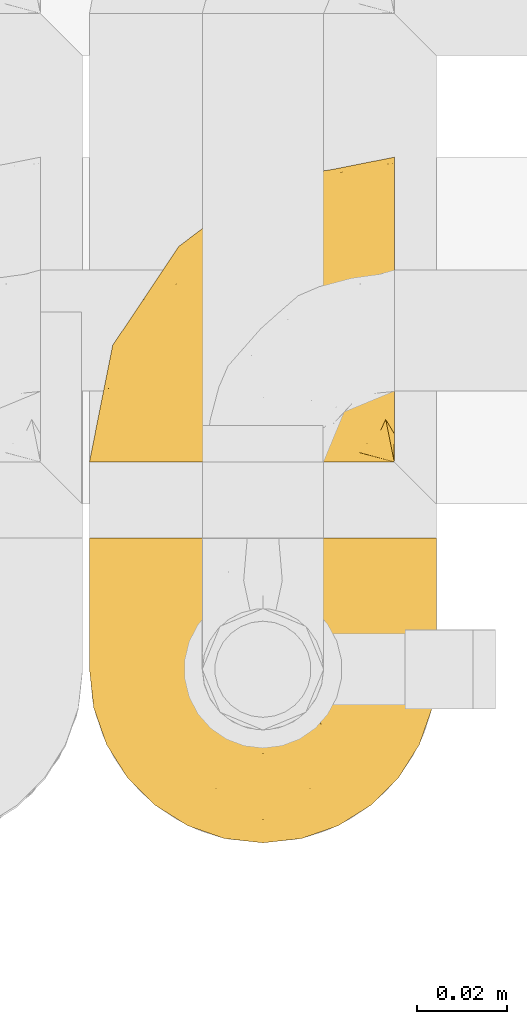
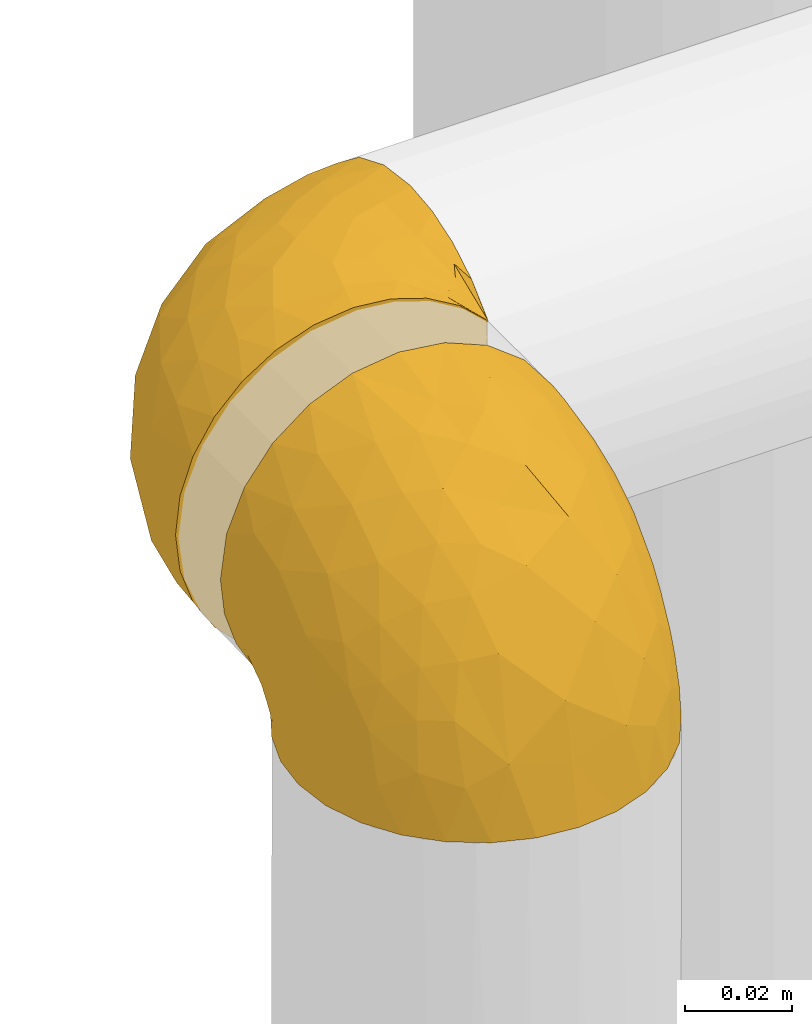
# One storey, part 464 of 827: 2 coverings.
"""IFC2X3 building model written with IfcOpenShell, lengths in millimetres."""

from ifc_helpers import new_model, entity, si_unit, converted_unit, derived_unit, direction, frame, origin, place, context, subcontext, project, spatial, faceted_brep, element, save


model = new_model("IFC2X3")

# Units and contexts
model_context = context("Model", 3, precision=0.01, world=origin(), true_north=direction((6.12303176911189e-17, 1.0)))
body_context = subcontext(model_context, "Body", "Model", "MODEL_VIEW")
ifc_project = project(units=[si_unit("LENGTHUNIT", "METRE", prefix="MILLI"), si_unit("AREAUNIT", "SQUARE_METRE"), si_unit("VOLUMEUNIT", "CUBIC_METRE"), converted_unit("PLANEANGLEUNIT", "DEGREE", entity("IfcRatioMeasure", 0.0174532925199433), si_unit("PLANEANGLEUNIT", "RADIAN"), dimensions=[0, 0, 0, 0, 0, 0, 0]), si_unit("MASSUNIT", "GRAM", prefix="KILO"), derived_unit("MASSDENSITYUNIT", [(si_unit("MASSUNIT", "GRAM", prefix="KILO"), 1), (si_unit("LENGTHUNIT", "METRE"), -3)]), derived_unit("MOMENTOFINERTIAUNIT", [(si_unit("LENGTHUNIT", "METRE"), 4)]), si_unit("TIMEUNIT", "SECOND"), si_unit("FREQUENCYUNIT", "HERTZ"), si_unit("THERMODYNAMICTEMPERATUREUNIT", "DEGREE_CELSIUS"), derived_unit("THERMALTRANSMITTANCEUNIT", [(si_unit("MASSUNIT", "GRAM", prefix="KILO"), 1), (si_unit("THERMODYNAMICTEMPERATUREUNIT", "KELVIN"), -1), (si_unit("TIMEUNIT", "SECOND"), -3)]), derived_unit("VOLUMETRICFLOWRATEUNIT", [(si_unit("LENGTHUNIT", "METRE"), 3), (si_unit("TIMEUNIT", "SECOND"), -1)]), derived_unit("MASSFLOWRATEUNIT", [(si_unit("MASSUNIT", "GRAM", prefix="KILO"), 1), (si_unit("TIMEUNIT", "SECOND"), -1)]), derived_unit("ROTATIONALFREQUENCYUNIT", [(si_unit("TIMEUNIT", "SECOND"), -1)]), si_unit("ELECTRICCURRENTUNIT", "AMPERE"), si_unit("ELECTRICVOLTAGEUNIT", "VOLT"), si_unit("POWERUNIT", "WATT"), si_unit("FORCEUNIT", "NEWTON", prefix="KILO"), si_unit("ILLUMINANCEUNIT", "LUX"), si_unit("LUMINOUSFLUXUNIT", "LUMEN"), si_unit("LUMINOUSINTENSITYUNIT", "CANDELA"), derived_unit("USERDEFINED", [(si_unit("MASSUNIT", "GRAM", prefix="KILO"), -1), (si_unit("LENGTHUNIT", "METRE"), -2), (si_unit("TIMEUNIT", "SECOND"), 3), (si_unit("LUMINOUSFLUXUNIT", "LUMEN"), 1)]), derived_unit("LINEARVELOCITYUNIT", [(si_unit("LENGTHUNIT", "METRE"), 1), (si_unit("TIMEUNIT", "SECOND"), -1)]), si_unit("PRESSUREUNIT", "PASCAL"), derived_unit("USERDEFINED", [(si_unit("LENGTHUNIT", "METRE"), -2), (si_unit("MASSUNIT", "GRAM", prefix="KILO"), 1), (si_unit("TIMEUNIT", "SECOND"), -2)]), derived_unit("LINEARFORCEUNIT", [(si_unit("MASSUNIT", "GRAM", prefix="KILO"), 1), (si_unit("LENGTHUNIT", "METRE"), 1), (si_unit("TIMEUNIT", "SECOND"), -2), (si_unit("LENGTHUNIT", "METRE"), -1)]), derived_unit("PLANARFORCEUNIT", [(si_unit("MASSUNIT", "GRAM", prefix="KILO"), 1), (si_unit("LENGTHUNIT", "METRE"), 1), (si_unit("TIMEUNIT", "SECOND"), -2), (si_unit("LENGTHUNIT", "METRE"), -2)])], contexts=[model_context])

# Site, building, storey
site_placement = place(None, origin())
site = spatial("IfcSite", under=ifc_project, at=site_placement, CompositionType="ELEMENT")
building_placement = place(site_placement, origin())
building = spatial("IfcBuilding", under=site, at=building_placement, CompositionType="ELEMENT")
storey_placement = place(building_placement, frame((0.0, 0.0, 28200.0)))
storey = spatial("IfcBuildingStorey", under=building, at=storey_placement, Name="08", CompositionType="ELEMENT", Elevation=28200.0)

# Coverings
covering_1_placement = place(storey_placement, frame((58529.55, 16349.14, 2609.95)))
element("IfcCovering", 1, at=covering_1_placement, inside=storey, Name=":ADSK_", ObjectType=":ADSK_", PredefinedType="INSULATION", context=body_context, shape_type="Brep", body=[
    faceted_brep([(23.36, 1.6, 74.68), (16.07, 1.6, 70.1), (9.98, 1.6, 64.01), (5.4, 1.6, 56.72), (2.56, 1.6, 48.6), (1.6, 1.6, 40.05), (2.56, 1.6, 31.49), (5.41, 1.6, 23.36), (9.99, 1.6, 16.07), (16.08, 1.6, 9.98), (23.37, 1.6, 5.4), (31.49, 1.6, 2.56), (40.05, 1.6, 1.6), (48.15, 1.6, 2.46), (55.88, 1.6, 5.01), (62.9, 1.6, 9.13), (68.89, 1.6, 14.62), (68.89, 1.6, 16.82), (68.89, 1.6, 18.56), (68.89, 1.6, 20.52), (68.89, 1.6, 22.49), (68.89, 1.6, 24.46), (68.89, 1.6, 26.42), (68.89, 1.6, 28.39), (68.89, 1.6, 30.36), (68.89, 1.6, 32.55), (68.89, 1.6, 34.75), (68.89, 1.6, 36.94), (68.89, 1.6, 39.13), (68.89, 1.6, 41.33), (68.89, 1.6, 43.52), (68.89, 1.6, 45.72), (68.89, 1.6, 47.91), (68.89, 1.6, 50.11), (68.89, 1.6, 52.3), (68.89, 1.6, 54.49), (68.89, 1.6, 56.69), (68.89, 1.6, 58.88), (68.89, 1.6, 61.08), (68.89, 1.6, 63.27), (68.89, 1.6, 65.47), (62.89, 1.6, 70.97), (55.86, 1.6, 75.09), (48.13, 1.6, 77.64), (40.05, 1.6, 78.5), (31.49, 1.6, 77.53), (69.15, 1.85, 14.62), (69.15, 7.85, 9.12), (69.15, 14.87, 5.0), (69.15, 22.6, 2.46), (69.15, 30.7, 1.6), (69.15, 40.65, 2.91), (69.15, 49.92, 6.75), (69.15, 57.88, 12.86), (69.15, 63.99, 20.82), (69.15, 67.84, 30.09), (69.15, 69.15, 40.05), (69.15, 67.84, 50.0), (69.15, 63.99, 59.27), (69.15, 57.88, 67.23), (69.15, 49.92, 73.34), (69.15, 40.65, 77.19), (69.15, 30.7, 78.5), (69.15, 22.6, 77.63), (69.15, 14.87, 75.09), (69.15, 7.85, 70.97), (69.15, 1.85, 65.47), (69.15, 1.85, 63.27), (69.15, 1.85, 62.29), (69.15, 1.85, 60.7), (69.15, 1.85, 59.11), (69.15, 1.85, 57.52), (69.15, 1.85, 55.93), (69.15, 1.85, 54.34), (69.15, 1.85, 52.76), (69.15, 1.85, 51.17), (69.15, 1.85, 49.58), (69.15, 1.85, 47.99), (69.15, 1.85, 46.4), (69.15, 1.85, 44.81), (69.15, 1.85, 43.22), (69.15, 1.85, 41.63), (69.15, 1.85, 40.05), (69.15, 1.85, 38.46), (69.15, 1.85, 36.87), (69.15, 1.85, 35.28), (69.15, 1.85, 33.69), (69.15, 1.85, 32.1), (69.15, 1.85, 30.51), (69.15, 1.85, 28.92), (69.15, 1.85, 27.33), (69.15, 1.85, 25.37), (69.15, 1.85, 23.4), (69.15, 1.85, 21.21), (69.15, 1.85, 19.01), (69.15, 1.85, 16.82), (68.96, 1.77, 42.32), (68.97, 1.78, 44.02), (68.97, 1.77, 47.13), (68.97, 1.77, 48.74), (68.95, 1.76, 23.57), (68.96, 1.77, 25.13), (68.98, 1.79, 61.34), (68.97, 1.78, 22.02), (68.97, 1.78, 29.72), (68.98, 1.78, 56.73), (68.97, 1.78, 55.14), (68.97, 1.78, 37.66), (68.94, 1.74, 64.12), (68.98, 1.78, 28.13), (68.98, 1.78, 26.62), (68.96, 1.77, 31.46), (68.97, 1.78, 16.16), (68.98, 1.78, 39.16), (68.98, 1.78, 50.37), (68.97, 1.77, 17.69), (68.96, 1.77, 19.17), (68.97, 1.77, 62.78), (68.97, 1.78, 58.35), (68.98, 1.78, 45.53), (68.96, 1.77, 59.91), (68.97, 1.77, 65.47), (68.94, 1.72, 65.47), (68.92, 1.66, 65.47), (68.97, 1.77, 14.62), (69.02, 1.8, 14.62), (69.08, 1.82, 14.62), (68.98, 1.79, 20.59), (68.97, 1.78, 32.99), (68.98, 1.79, 34.48), (68.97, 1.78, 51.91), (69.08, 1.82, 65.47), (69.02, 1.8, 65.47), (68.96, 1.76, 53.48), (68.92, 1.66, 14.62), (68.94, 1.72, 14.62), (68.97, 1.78, 40.77), (68.96, 1.77, 35.97), (67.02, 9.41, 7.84), (63.33, 17.65, 3.53), (64.61, 7.41, 8.32), (49.27, 21.47, 1.6), (51.4, 15.21, 2.19), (43.94, 16.15, 1.6), (61.87, 28.75, 1.6), (61.54, 13.67, 4.57), (57.95, 12.79, 3.96), (56.12, 19.18, 2.28), (63.4, 29.16, 1.6), (65.41, 9.04, 7.69), (53.1, 7.41, 3.53), (63.04, 5.74, 8.32), (61.33, 3.72, 7.84), (41.99, 8.87, 1.6), (54.6, 26.8, 1.6), (56.6, 9.53, 4.34), (41.58, 7.34, 1.6), (13.72, 37.63, 29.63), (5.82, 17.92, 27.34), (6.74, 27.45, 40.05), (58.82, 37.01, 2.39), (51.58, 34.22, 2.43), (42.09, 45.87, 9.07), (46.12, 56.57, 16.64), (55.56, 52.31, 9.54), (52.38, 42.07, 4.52), (61.54, 44.74, 4.52), (23.76, 21.49, 7.49), (20.5, 11.02, 7.49), (14.64, 15.64, 12.85), (41.77, 26.02, 2.35), (16.28, 36.59, 22.66), (49.4, 65.49, 32.9), (52.34, 63.99, 25.33), (4.3, 15.2, 40.05), (58.67, 60.27, 16.64), (25.26, 45.25, 19.99), (20.17, 35.21, 16.37), (34.7, 22.52, 3.26), (28.67, 12.03, 3.75), (8.62, 13.32, 19.58), (33.37, 35.9, 7.5), (41.35, 33.87, 4.04), (17.15, 25.73, 13.94), (12.68, 26.34, 19.58), (21.47, 46.78, 28.21), (41.11, 59.54, 24.75), (37.53, 60.18, 31.42), (30.64, 53.93, 26.2), (26.66, 53.36, 33.36), (21.38, 49.36, 40.05), (14.06, 38.4, 40.05), (55.54, 66.44, 40.05), (35.17, 50.09, 16.14), (29.04, 41.08, 12.85), (24.34, 31.14, 10.47), (29.33, 28.19, 6.49), (43.3, 64.0, 40.05), (32.34, 56.68, 40.05), (57.75, 43.9, 75.57), (49.41, 65.46, 47.37), (27.85, 52.22, 52.91), (13.7, 37.61, 50.46), (14.63, 15.64, 67.23), (8.61, 13.31, 60.5), (48.85, 50.02, 70.55), (54.13, 59.28, 63.45), (37.84, 53.05, 62.61), (23.75, 21.48, 72.6), (20.49, 11.01, 72.6), (28.66, 12.03, 76.34), (20.83, 41.02, 59.34), (55.15, 35.39, 77.76), (54.6, 26.8, 78.5), (61.87, 28.75, 78.5), (41.58, 7.34, 78.5), (57.58, 65.81, 53.16), (59.91, 53.28, 70.55), (36.94, 59.8, 48.88), (45.72, 61.82, 54.76), (5.82, 17.91, 52.74), (37.91, 41.4, 71.93), (50.18, 40.48, 75.79), (12.67, 26.34, 60.5), (49.29, 31.68, 77.86), (42.64, 27.68, 77.64), (43.94, 16.15, 78.5), (49.27, 21.47, 78.5), (19.45, 28.05, 67.23), (34.7, 22.54, 76.82), (41.99, 8.87, 78.5), (62.29, 37.3, 77.8), (29.01, 41.07, 67.23), (31.47, 32.24, 73.2), (37.18, 47.4, 67.66), (43.45, 35.77, 75.99), (63.33, 17.65, 76.57), (67.23, 11.06, 73.21), (66.07, 8.55, 71.93), (65.22, 6.63, 71.07), (61.99, 12.77, 75.09), (57.95, 12.79, 76.13), (53.09, 7.41, 76.57), (56.84, 18.97, 77.69), (61.33, 3.72, 72.26), (63.06, 5.76, 71.77), (51.41, 15.21, 77.9), (56.61, 9.52, 75.75)], [[[0, 1, 2, 3, 4, 5, 6, 7, 8, 9, 10, 11, 12, 13, 14, 15, 16, 17, 18, 19, 20, 21, 22, 23, 24, 25, 26, 27, 28, 29, 30, 31, 32, 33, 34, 35, 36, 37, 38, 39, 40, 41, 42, 43, 44, 45]], [[46, 47, 48, 49, 50, 51, 52, 53, 54, 55, 56, 57, 58, 59, 60, 61, 62, 63, 64, 65, 66, 67, 68, 69, 70, 71, 72, 73, 74, 75, 76, 77, 78, 79, 80, 81, 82, 83, 84, 85, 86, 87, 88, 89, 90, 91, 92, 93, 94, 95]], [[96, 97, 30]], [[98, 77, 99]], [[100, 101, 21]], [[69, 68, 102]], [[20, 19, 103]], [[24, 23, 104]], [[20, 103, 100]], [[72, 105, 106]], [[84, 83, 107]], [[89, 88, 104]], [[108, 67, 66]], [[109, 110, 90]], [[111, 25, 24]], [[112, 17, 16]], [[82, 113, 83]], [[109, 23, 22]], [[114, 76, 75]], [[105, 36, 106]], [[104, 111, 24]], [[18, 115, 116]], [[97, 96, 80]], [[67, 108, 117]], [[105, 71, 118]], [[31, 97, 119]], [[102, 120, 69]], [[108, 121, 122, 123, 40]], [[112, 95, 115]], [[17, 115, 18]], [[94, 116, 115]], [[117, 68, 67]], [[38, 117, 39]], [[112, 124, 125, 126, 46]], [[17, 112, 115]], [[70, 120, 118]], [[39, 117, 108]], [[120, 38, 37]], [[120, 37, 118]], [[120, 70, 69]], [[116, 94, 127]], [[128, 86, 129]], [[117, 38, 102]], [[74, 130, 75]], [[99, 33, 32]], [[115, 95, 94]], [[39, 108, 40]], [[108, 66, 131, 132, 121]], [[105, 72, 71]], [[118, 37, 36]], [[71, 70, 118]], [[35, 106, 36]], [[36, 105, 118]], [[35, 133, 106]], [[74, 73, 133]], [[106, 133, 73]], [[99, 114, 33]], [[133, 35, 34]], [[73, 72, 106]], [[95, 112, 46]], [[112, 16, 134, 135, 124]], [[130, 114, 75]], [[99, 76, 114]], [[114, 130, 33]], [[34, 33, 130]], [[78, 77, 98]], [[98, 119, 78]], [[130, 133, 34]], [[133, 130, 74]], [[79, 97, 80]], [[98, 99, 32]], [[98, 32, 31]], [[77, 76, 99]], [[97, 79, 119]], [[136, 96, 29]], [[30, 97, 31]], [[136, 29, 28]], [[81, 80, 96]], [[29, 96, 30]], [[31, 119, 98]], [[119, 79, 78]], [[96, 136, 81]], [[82, 81, 136]], [[113, 107, 83]], [[84, 107, 137]], [[107, 27, 137]], [[113, 28, 107]], [[27, 107, 28]], [[85, 84, 137]], [[137, 27, 26]], [[113, 136, 28]], [[136, 113, 82]], [[109, 89, 104]], [[86, 85, 129]], [[89, 109, 90]], [[111, 87, 128]], [[26, 129, 137]], [[88, 111, 104]], [[25, 111, 128]], [[22, 110, 109]], [[23, 109, 104]], [[110, 91, 90]], [[100, 92, 101]], [[110, 22, 101]], [[91, 110, 101]], [[116, 19, 18]], [[111, 88, 87]], [[127, 103, 19]], [[25, 128, 26]], [[86, 128, 87]], [[128, 129, 26]], [[137, 129, 85]], [[120, 102, 38]], [[117, 102, 68]], [[91, 101, 92]], [[21, 101, 22]], [[93, 92, 103]], [[100, 21, 20]], [[100, 103, 92]], [[127, 93, 103]], [[93, 127, 94]], [[116, 127, 19]], [[126, 138, 47]], [[48, 138, 139]], [[140, 125, 124]], [[141, 142, 143]], [[144, 49, 139]], [[145, 140, 146]], [[48, 139, 49]], [[139, 145, 147]], [[49, 144, 148, 50]], [[126, 125, 149]], [[14, 13, 150]], [[151, 146, 140]], [[149, 140, 145]], [[152, 151, 135]], [[152, 14, 150]], [[16, 15, 134]], [[13, 153, 150]], [[124, 151, 140]], [[141, 147, 142]], [[14, 152, 15]], [[15, 152, 134]], [[47, 46, 126]], [[139, 154, 144]], [[138, 48, 47]], [[125, 140, 149]], [[135, 134, 152]], [[146, 155, 142]], [[145, 146, 147]], [[149, 139, 138]], [[147, 141, 154]], [[147, 146, 142]], [[139, 147, 154]], [[139, 149, 145]], [[149, 138, 126]], [[155, 146, 151]], [[150, 143, 142]], [[152, 155, 151]], [[150, 142, 155]], [[13, 12, 156, 153]], [[153, 143, 150]], [[152, 150, 155]], [[151, 124, 135]], [[157, 158, 159]], [[160, 154, 161]], [[162, 163, 164]], [[165, 166, 160]], [[167, 168, 169]], [[141, 170, 161]], [[156, 12, 11]], [[158, 157, 171]], [[172, 55, 173]], [[158, 6, 174]], [[175, 54, 53]], [[52, 166, 164]], [[52, 164, 53]], [[54, 175, 173]], [[166, 52, 51]], [[176, 177, 171]], [[178, 143, 179]], [[156, 11, 179]], [[8, 7, 180]], [[169, 9, 8]], [[179, 143, 153, 156]], [[179, 11, 10]], [[168, 179, 10]], [[181, 162, 182]], [[179, 167, 178]], [[183, 184, 177]], [[183, 169, 184]], [[176, 171, 185]], [[172, 186, 187]], [[158, 7, 6]], [[159, 158, 174]], [[184, 180, 158]], [[54, 173, 55]], [[180, 169, 8]], [[188, 189, 187]], [[9, 168, 10]], [[186, 188, 187]], [[190, 157, 159, 191]], [[55, 172, 192]], [[176, 193, 194]], [[161, 170, 182]], [[162, 164, 165]], [[175, 164, 163]], [[51, 50, 148]], [[167, 195, 196]], [[178, 182, 170]], [[6, 5, 174]], [[158, 180, 7]], [[169, 180, 184]], [[169, 168, 9]], [[179, 168, 167]], [[182, 162, 165]], [[162, 194, 193]], [[161, 165, 160]], [[195, 181, 196]], [[192, 172, 197]], [[192, 56, 55]], [[189, 190, 198]], [[198, 197, 187]], [[172, 187, 197]], [[185, 189, 188]], [[198, 187, 189]], [[186, 172, 173]], [[173, 163, 186]], [[193, 186, 163]], [[176, 185, 188]], [[185, 157, 190]], [[188, 186, 193]], [[177, 176, 194]], [[188, 193, 176]], [[162, 193, 163]], [[195, 177, 194]], [[171, 177, 184]], [[181, 195, 194]], [[183, 167, 169]], [[162, 181, 194]], [[196, 182, 178]], [[158, 171, 184]], [[171, 157, 185]], [[177, 195, 183]], [[167, 183, 195]], [[182, 196, 181]], [[178, 170, 143]], [[178, 167, 196]], [[164, 175, 53]], [[173, 175, 163]], [[160, 51, 148]], [[164, 166, 165]], [[51, 160, 166]], [[160, 148, 144, 154]], [[141, 161, 154]], [[182, 165, 161]], [[190, 189, 185]], [[143, 170, 141]], [[60, 199, 61]], [[197, 200, 192]], [[201, 190, 202]], [[200, 57, 192]], [[203, 204, 2]], [[205, 206, 207]], [[208, 209, 210]], [[211, 207, 201]], [[212, 213, 214]], [[45, 215, 210]], [[216, 206, 58]], [[45, 44, 215]], [[59, 217, 60]], [[60, 217, 199]], [[0, 45, 210]], [[218, 201, 219]], [[202, 159, 220]], [[205, 221, 222]], [[223, 204, 203]], [[1, 203, 2]], [[57, 200, 216]], [[220, 3, 204]], [[220, 174, 4]], [[1, 0, 209]], [[212, 224, 213]], [[225, 226, 227]], [[228, 223, 203]], [[208, 210, 229]], [[210, 226, 229]], [[3, 220, 4]], [[58, 206, 59]], [[209, 203, 1]], [[202, 220, 223]], [[228, 203, 208]], [[202, 211, 201]], [[3, 2, 204]], [[202, 190, 191, 159]], [[210, 215, 230, 226]], [[199, 212, 231]], [[232, 233, 221]], [[233, 208, 229]], [[207, 206, 219]], [[217, 206, 205]], [[227, 224, 225]], [[233, 232, 228]], [[201, 207, 219]], [[234, 232, 221]], [[218, 219, 200]], [[202, 223, 211]], [[174, 220, 159]], [[174, 5, 4]], [[61, 231, 62]], [[220, 204, 223]], [[210, 209, 0]], [[203, 209, 208]], [[225, 233, 229]], [[224, 227, 213]], [[221, 233, 235]], [[57, 56, 192]], [[198, 218, 197]], [[200, 219, 216]], [[201, 198, 190]], [[197, 218, 200]], [[198, 201, 218]], [[206, 216, 219]], [[58, 57, 216]], [[231, 212, 214]], [[222, 212, 199]], [[228, 211, 223]], [[207, 211, 232]], [[62, 231, 214]], [[199, 231, 61]], [[233, 228, 208]], [[211, 228, 232]], [[222, 221, 235]], [[234, 205, 207]], [[206, 217, 59]], [[199, 217, 205]], [[205, 222, 199]], [[224, 222, 235]], [[222, 224, 212]], [[224, 235, 225]], [[233, 225, 235]], [[226, 225, 229]], [[205, 234, 221]], [[207, 232, 234]], [[63, 214, 236]], [[214, 213, 236]], [[214, 63, 62]], [[237, 236, 238]], [[238, 132, 131]], [[236, 237, 64]], [[239, 240, 241]], [[63, 236, 64]], [[131, 66, 65]], [[237, 131, 65]], [[242, 230, 43]], [[237, 65, 64]], [[239, 121, 132]], [[42, 242, 43]], [[241, 240, 243]], [[41, 123, 244]], [[43, 230, 215, 44]], [[244, 122, 245]], [[227, 246, 243]], [[241, 247, 245]], [[121, 239, 245]], [[41, 40, 123]], [[132, 238, 239]], [[244, 42, 41]], [[131, 237, 238]], [[240, 239, 238]], [[245, 239, 241]], [[247, 241, 246]], [[247, 244, 245]], [[238, 236, 240]], [[243, 236, 213]], [[236, 243, 240]], [[227, 226, 246]], [[243, 213, 227]], [[242, 246, 226]], [[243, 246, 241]], [[246, 242, 247]], [[244, 247, 242]], [[242, 226, 230]], [[42, 244, 242]], [[122, 244, 123]], [[122, 121, 245]]]),
])
covering_2_placement = place(storey_placement, frame((58529.55, 16264.79, 2619.3)))
element("IfcCovering", 2, at=covering_2_placement, inside=storey, Name=":ADSK_", ObjectType=":ADSK_", PredefinedType="INSULATION", context=body_context, shape_type="Brep", body=[
    faceted_brep([(74.68, 23.36, 1.6), (70.1, 16.07, 1.6), (64.01, 9.98, 1.6), (56.72, 5.4, 1.6), (48.6, 2.56, 1.6), (40.05, 1.6, 1.6), (31.49, 2.56, 1.6), (23.36, 5.41, 1.6), (16.07, 9.99, 1.6), (9.98, 16.08, 1.6), (5.4, 23.37, 1.6), (2.56, 31.49, 1.6), (1.6, 40.05, 1.6), (2.46, 48.15, 1.6), (5.01, 55.88, 1.6), (9.13, 62.9, 1.6), (14.62, 68.89, 1.6), (16.82, 68.89, 1.6), (18.56, 68.89, 1.6), (20.52, 68.89, 1.6), (22.49, 68.89, 1.6), (24.46, 68.89, 1.6), (26.42, 68.89, 1.6), (28.39, 68.89, 1.6), (30.36, 68.89, 1.6), (32.55, 68.89, 1.6), (34.75, 68.89, 1.6), (36.94, 68.89, 1.6), (39.13, 68.89, 1.6), (41.33, 68.89, 1.6), (43.52, 68.89, 1.6), (45.72, 68.89, 1.6), (47.91, 68.89, 1.6), (50.11, 68.89, 1.6), (52.3, 68.89, 1.6), (54.49, 68.89, 1.6), (56.69, 68.89, 1.6), (58.88, 68.89, 1.6), (61.08, 68.89, 1.6), (63.27, 68.89, 1.6), (65.47, 68.89, 1.6), (70.97, 62.89, 1.6), (75.09, 55.86, 1.6), (77.64, 48.13, 1.6), (78.5, 40.05, 1.6), (77.53, 31.49, 1.6), (14.62, 69.15, 1.85), (9.12, 69.15, 7.85), (5.0, 69.15, 14.87), (2.46, 69.15, 22.6), (1.6, 69.15, 30.7), (2.91, 69.15, 40.65), (6.75, 69.15, 49.92), (12.86, 69.15, 57.88), (20.82, 69.15, 63.99), (30.09, 69.15, 67.84), (40.05, 69.15, 69.15), (50.0, 69.15, 67.84), (59.27, 69.15, 63.99), (67.23, 69.15, 57.88), (73.34, 69.15, 49.92), (77.19, 69.15, 40.65), (78.5, 69.15, 30.7), (77.63, 69.15, 22.6), (75.09, 69.15, 14.87), (70.97, 69.15, 7.85), (65.47, 69.15, 1.85), (63.27, 69.15, 1.85), (62.29, 69.15, 1.85), (60.7, 69.15, 1.85), (59.11, 69.15, 1.85), (57.52, 69.15, 1.85), (55.93, 69.15, 1.85), (54.34, 69.15, 1.85), (52.76, 69.15, 1.85), (51.17, 69.15, 1.85), (49.58, 69.15, 1.85), (47.99, 69.15, 1.85), (46.4, 69.15, 1.85), (44.81, 69.15, 1.85), (43.22, 69.15, 1.85), (41.63, 69.15, 1.85), (40.05, 69.15, 1.85), (38.46, 69.15, 1.85), (36.87, 69.15, 1.85), (35.28, 69.15, 1.85), (33.69, 69.15, 1.85), (32.1, 69.15, 1.85), (30.51, 69.15, 1.85), (28.92, 69.15, 1.85), (27.33, 69.15, 1.85), (25.37, 69.15, 1.85), (23.4, 69.15, 1.85), (21.21, 69.15, 1.85), (19.01, 69.15, 1.85), (16.82, 69.15, 1.85), (42.32, 68.96, 1.77), (44.02, 68.97, 1.78), (47.13, 68.97, 1.77), (48.74, 68.97, 1.77), (23.57, 68.95, 1.76), (25.13, 68.96, 1.77), (61.34, 68.98, 1.79), (22.02, 68.97, 1.78), (29.72, 68.97, 1.78), (56.73, 68.98, 1.78), (55.14, 68.97, 1.78), (37.66, 68.97, 1.78), (64.12, 68.94, 1.74), (28.13, 68.98, 1.78), (26.62, 68.98, 1.78), (31.46, 68.96, 1.77), (16.16, 68.97, 1.78), (39.16, 68.98, 1.78), (50.37, 68.98, 1.78), (17.69, 68.97, 1.77), (19.17, 68.96, 1.77), (62.78, 68.97, 1.77), (58.35, 68.97, 1.78), (45.53, 68.98, 1.78), (59.91, 68.96, 1.77), (65.47, 68.97, 1.77), (65.47, 68.94, 1.72), (65.47, 68.92, 1.66), (14.62, 68.97, 1.77), (14.62, 69.02, 1.8), (14.62, 69.08, 1.82), (20.59, 68.98, 1.79), (32.99, 68.97, 1.78), (34.48, 68.98, 1.79), (51.91, 68.97, 1.78), (65.47, 69.08, 1.82), (65.47, 69.02, 1.8), (53.48, 68.96, 1.76), (14.62, 68.92, 1.66), (14.62, 68.94, 1.72), (40.77, 68.97, 1.78), (35.97, 68.96, 1.77), (7.84, 67.02, 9.41), (3.53, 63.33, 17.65), (8.32, 64.61, 7.41), (1.6, 49.27, 21.47), (2.19, 51.4, 15.21), (1.6, 43.94, 16.15), (1.6, 61.87, 28.75), (4.57, 61.54, 13.67), (3.96, 57.95, 12.79), (2.28, 56.12, 19.18), (1.6, 63.4, 29.16), (7.69, 65.41, 9.04), (3.53, 53.1, 7.41), (8.32, 63.04, 5.74), (7.84, 61.33, 3.72), (1.6, 41.99, 8.87), (1.6, 54.6, 26.8), (4.34, 56.6, 9.53), (1.6, 41.58, 7.34), (29.63, 13.72, 37.63), (27.34, 5.82, 17.92), (40.05, 6.74, 27.45), (2.39, 58.82, 37.01), (2.43, 51.58, 34.22), (9.07, 42.09, 45.87), (16.64, 46.12, 56.57), (9.54, 55.56, 52.31), (4.52, 52.38, 42.07), (4.52, 61.54, 44.74), (7.49, 23.76, 21.49), (7.49, 20.5, 11.02), (12.85, 14.64, 15.64), (2.35, 41.77, 26.02), (22.66, 16.28, 36.59), (32.9, 49.4, 65.49), (25.33, 52.34, 63.99), (40.05, 4.3, 15.2), (16.64, 58.67, 60.27), (19.99, 25.26, 45.25), (16.37, 20.17, 35.21), (3.26, 34.7, 22.52), (3.75, 28.67, 12.03), (19.58, 8.62, 13.32), (7.5, 33.37, 35.9), (4.04, 41.35, 33.87), (13.94, 17.15, 25.73), (19.58, 12.68, 26.34), (28.21, 21.47, 46.78), (24.75, 41.11, 59.54), (31.42, 37.53, 60.18), (26.2, 30.64, 53.93), (33.36, 26.66, 53.36), (40.05, 21.38, 49.36), (40.05, 14.06, 38.4), (40.05, 55.54, 66.44), (16.14, 35.17, 50.09), (12.85, 29.04, 41.08), (10.47, 24.34, 31.14), (6.49, 29.33, 28.19), (40.05, 43.3, 64.0), (40.05, 32.34, 56.68), (75.57, 57.75, 43.9), (47.37, 49.41, 65.46), (52.91, 27.85, 52.22), (50.46, 13.7, 37.61), (67.23, 14.63, 15.64), (60.5, 8.61, 13.31), (70.55, 48.85, 50.02), (63.45, 54.13, 59.28), (62.61, 37.84, 53.05), (72.6, 23.75, 21.48), (72.6, 20.49, 11.01), (76.34, 28.66, 12.03), (59.34, 20.83, 41.02), (77.76, 55.15, 35.39), (78.5, 54.6, 26.8), (78.5, 61.87, 28.75), (78.5, 41.58, 7.34), (53.16, 57.58, 65.81), (70.55, 59.91, 53.28), (48.88, 36.94, 59.8), (54.76, 45.72, 61.82), (52.74, 5.82, 17.91), (71.93, 37.91, 41.4), (75.79, 50.18, 40.48), (60.5, 12.67, 26.34), (77.86, 49.29, 31.68), (77.64, 42.64, 27.68), (78.5, 43.94, 16.15), (78.5, 49.27, 21.47), (67.23, 19.45, 28.05), (76.82, 34.7, 22.54), (78.5, 41.99, 8.87), (77.8, 62.29, 37.3), (67.23, 29.01, 41.07), (73.2, 31.47, 32.24), (67.66, 37.18, 47.4), (75.99, 43.45, 35.77), (76.57, 63.33, 17.65), (73.21, 67.23, 11.06), (71.93, 66.07, 8.55), (71.07, 65.22, 6.63), (75.09, 61.99, 12.77), (76.13, 57.95, 12.79), (76.57, 53.09, 7.41), (77.69, 56.84, 18.97), (72.26, 61.33, 3.72), (71.77, 63.06, 5.76), (77.9, 51.41, 15.21), (75.75, 56.61, 9.52)], [[[0, 1, 2, 3, 4, 5, 6, 7, 8, 9, 10, 11, 12, 13, 14, 15, 16, 17, 18, 19, 20, 21, 22, 23, 24, 25, 26, 27, 28, 29, 30, 31, 32, 33, 34, 35, 36, 37, 38, 39, 40, 41, 42, 43, 44, 45]], [[46, 47, 48, 49, 50, 51, 52, 53, 54, 55, 56, 57, 58, 59, 60, 61, 62, 63, 64, 65, 66, 67, 68, 69, 70, 71, 72, 73, 74, 75, 76, 77, 78, 79, 80, 81, 82, 83, 84, 85, 86, 87, 88, 89, 90, 91, 92, 93, 94, 95]], [[96, 97, 30]], [[98, 77, 99]], [[100, 101, 21]], [[69, 68, 102]], [[20, 19, 103]], [[24, 23, 104]], [[20, 103, 100]], [[72, 105, 106]], [[84, 83, 107]], [[89, 88, 104]], [[108, 67, 66]], [[109, 110, 90]], [[111, 25, 24]], [[112, 17, 16]], [[82, 113, 83]], [[109, 23, 22]], [[114, 76, 75]], [[105, 36, 106]], [[104, 111, 24]], [[18, 115, 116]], [[97, 96, 80]], [[67, 108, 117]], [[105, 71, 118]], [[31, 97, 119]], [[102, 120, 69]], [[108, 121, 122, 123, 40]], [[112, 95, 115]], [[17, 115, 18]], [[94, 116, 115]], [[117, 68, 67]], [[38, 117, 39]], [[112, 124, 125, 126, 46]], [[17, 112, 115]], [[70, 120, 118]], [[39, 117, 108]], [[120, 38, 37]], [[120, 37, 118]], [[120, 70, 69]], [[116, 94, 127]], [[128, 86, 129]], [[117, 38, 102]], [[74, 130, 75]], [[99, 33, 32]], [[115, 95, 94]], [[39, 108, 40]], [[108, 66, 131, 132, 121]], [[105, 72, 71]], [[118, 37, 36]], [[71, 70, 118]], [[35, 106, 36]], [[36, 105, 118]], [[35, 133, 106]], [[74, 73, 133]], [[106, 133, 73]], [[99, 114, 33]], [[133, 35, 34]], [[73, 72, 106]], [[95, 112, 46]], [[112, 16, 134, 135, 124]], [[130, 114, 75]], [[99, 76, 114]], [[114, 130, 33]], [[34, 33, 130]], [[78, 77, 98]], [[98, 119, 78]], [[130, 133, 34]], [[133, 130, 74]], [[79, 97, 80]], [[98, 99, 32]], [[98, 32, 31]], [[77, 76, 99]], [[97, 79, 119]], [[136, 96, 29]], [[30, 97, 31]], [[136, 29, 28]], [[81, 80, 96]], [[29, 96, 30]], [[31, 119, 98]], [[119, 79, 78]], [[96, 136, 81]], [[82, 81, 136]], [[113, 107, 83]], [[84, 107, 137]], [[107, 27, 137]], [[113, 28, 107]], [[27, 107, 28]], [[85, 84, 137]], [[137, 27, 26]], [[113, 136, 28]], [[136, 113, 82]], [[109, 89, 104]], [[86, 85, 129]], [[89, 109, 90]], [[111, 87, 128]], [[26, 129, 137]], [[88, 111, 104]], [[25, 111, 128]], [[22, 110, 109]], [[23, 109, 104]], [[110, 91, 90]], [[100, 92, 101]], [[110, 22, 101]], [[91, 110, 101]], [[116, 19, 18]], [[111, 88, 87]], [[127, 103, 19]], [[25, 128, 26]], [[86, 128, 87]], [[128, 129, 26]], [[137, 129, 85]], [[120, 102, 38]], [[117, 102, 68]], [[91, 101, 92]], [[21, 101, 22]], [[93, 92, 103]], [[100, 21, 20]], [[100, 103, 92]], [[127, 93, 103]], [[93, 127, 94]], [[116, 127, 19]], [[126, 138, 47]], [[48, 138, 139]], [[140, 125, 124]], [[141, 142, 143]], [[144, 49, 139]], [[145, 140, 146]], [[48, 139, 49]], [[139, 145, 147]], [[49, 144, 148, 50]], [[126, 125, 149]], [[14, 13, 150]], [[151, 146, 140]], [[149, 140, 145]], [[152, 151, 135]], [[152, 14, 150]], [[16, 15, 134]], [[13, 153, 150]], [[124, 151, 140]], [[141, 147, 142]], [[14, 152, 15]], [[15, 152, 134]], [[47, 46, 126]], [[139, 154, 144]], [[138, 48, 47]], [[125, 140, 149]], [[135, 134, 152]], [[146, 155, 142]], [[145, 146, 147]], [[149, 139, 138]], [[147, 141, 154]], [[147, 146, 142]], [[139, 147, 154]], [[139, 149, 145]], [[149, 138, 126]], [[155, 146, 151]], [[150, 143, 142]], [[152, 155, 151]], [[150, 142, 155]], [[13, 12, 156, 153]], [[153, 143, 150]], [[152, 150, 155]], [[151, 124, 135]], [[157, 158, 159]], [[160, 154, 161]], [[162, 163, 164]], [[165, 166, 160]], [[167, 168, 169]], [[141, 170, 161]], [[156, 12, 11]], [[158, 157, 171]], [[172, 55, 173]], [[158, 6, 174]], [[175, 54, 53]], [[52, 166, 164]], [[52, 164, 53]], [[54, 175, 173]], [[166, 52, 51]], [[176, 177, 171]], [[178, 143, 179]], [[156, 11, 179]], [[8, 7, 180]], [[169, 9, 8]], [[179, 143, 153, 156]], [[179, 11, 10]], [[168, 179, 10]], [[181, 162, 182]], [[179, 167, 178]], [[183, 184, 177]], [[183, 169, 184]], [[176, 171, 185]], [[172, 186, 187]], [[158, 7, 6]], [[159, 158, 174]], [[184, 180, 158]], [[54, 173, 55]], [[180, 169, 8]], [[188, 189, 187]], [[9, 168, 10]], [[186, 188, 187]], [[190, 157, 159, 191]], [[55, 172, 192]], [[176, 193, 194]], [[161, 170, 182]], [[162, 164, 165]], [[175, 164, 163]], [[51, 50, 148]], [[167, 195, 196]], [[178, 182, 170]], [[6, 5, 174]], [[158, 180, 7]], [[169, 180, 184]], [[169, 168, 9]], [[179, 168, 167]], [[182, 162, 165]], [[162, 194, 193]], [[161, 165, 160]], [[195, 181, 196]], [[192, 172, 197]], [[192, 56, 55]], [[189, 190, 198]], [[198, 197, 187]], [[172, 187, 197]], [[185, 189, 188]], [[198, 187, 189]], [[186, 172, 173]], [[173, 163, 186]], [[193, 186, 163]], [[176, 185, 188]], [[185, 157, 190]], [[188, 186, 193]], [[177, 176, 194]], [[188, 193, 176]], [[162, 193, 163]], [[195, 177, 194]], [[171, 177, 184]], [[181, 195, 194]], [[183, 167, 169]], [[162, 181, 194]], [[196, 182, 178]], [[158, 171, 184]], [[171, 157, 185]], [[177, 195, 183]], [[167, 183, 195]], [[182, 196, 181]], [[178, 170, 143]], [[178, 167, 196]], [[164, 175, 53]], [[173, 175, 163]], [[160, 51, 148]], [[164, 166, 165]], [[51, 160, 166]], [[160, 148, 144, 154]], [[141, 161, 154]], [[182, 165, 161]], [[190, 189, 185]], [[143, 170, 141]], [[60, 199, 61]], [[197, 200, 192]], [[201, 190, 202]], [[200, 57, 192]], [[203, 204, 2]], [[205, 206, 207]], [[208, 209, 210]], [[211, 207, 201]], [[212, 213, 214]], [[45, 215, 210]], [[216, 206, 58]], [[45, 44, 215]], [[59, 217, 60]], [[60, 217, 199]], [[0, 45, 210]], [[218, 201, 219]], [[202, 159, 220]], [[205, 221, 222]], [[223, 204, 203]], [[1, 203, 2]], [[57, 200, 216]], [[220, 3, 204]], [[220, 174, 4]], [[1, 0, 209]], [[212, 224, 213]], [[225, 226, 227]], [[228, 223, 203]], [[208, 210, 229]], [[210, 226, 229]], [[3, 220, 4]], [[58, 206, 59]], [[209, 203, 1]], [[202, 220, 223]], [[228, 203, 208]], [[202, 211, 201]], [[3, 2, 204]], [[202, 190, 191, 159]], [[210, 215, 230, 226]], [[199, 212, 231]], [[232, 233, 221]], [[233, 208, 229]], [[207, 206, 219]], [[217, 206, 205]], [[227, 224, 225]], [[233, 232, 228]], [[201, 207, 219]], [[234, 232, 221]], [[218, 219, 200]], [[202, 223, 211]], [[174, 220, 159]], [[174, 5, 4]], [[61, 231, 62]], [[220, 204, 223]], [[210, 209, 0]], [[203, 209, 208]], [[225, 233, 229]], [[224, 227, 213]], [[221, 233, 235]], [[57, 56, 192]], [[198, 218, 197]], [[200, 219, 216]], [[201, 198, 190]], [[197, 218, 200]], [[198, 201, 218]], [[206, 216, 219]], [[58, 57, 216]], [[231, 212, 214]], [[222, 212, 199]], [[228, 211, 223]], [[207, 211, 232]], [[62, 231, 214]], [[199, 231, 61]], [[233, 228, 208]], [[211, 228, 232]], [[222, 221, 235]], [[234, 205, 207]], [[206, 217, 59]], [[199, 217, 205]], [[205, 222, 199]], [[224, 222, 235]], [[222, 224, 212]], [[224, 235, 225]], [[233, 225, 235]], [[226, 225, 229]], [[205, 234, 221]], [[207, 232, 234]], [[63, 214, 236]], [[214, 213, 236]], [[214, 63, 62]], [[237, 236, 238]], [[238, 132, 131]], [[236, 237, 64]], [[239, 240, 241]], [[63, 236, 64]], [[131, 66, 65]], [[237, 131, 65]], [[242, 230, 43]], [[237, 65, 64]], [[239, 121, 132]], [[42, 242, 43]], [[241, 240, 243]], [[41, 123, 244]], [[43, 230, 215, 44]], [[244, 122, 245]], [[227, 246, 243]], [[241, 247, 245]], [[121, 239, 245]], [[41, 40, 123]], [[132, 238, 239]], [[244, 42, 41]], [[131, 237, 238]], [[240, 239, 238]], [[245, 239, 241]], [[247, 241, 246]], [[247, 244, 245]], [[238, 236, 240]], [[243, 236, 213]], [[236, 243, 240]], [[227, 226, 246]], [[243, 213, 227]], [[242, 246, 226]], [[243, 246, 241]], [[246, 242, 247]], [[244, 247, 242]], [[242, 226, 230]], [[42, 244, 242]], [[122, 244, 123]], [[122, 121, 245]]]),
])

save(model, "model.ifc")
